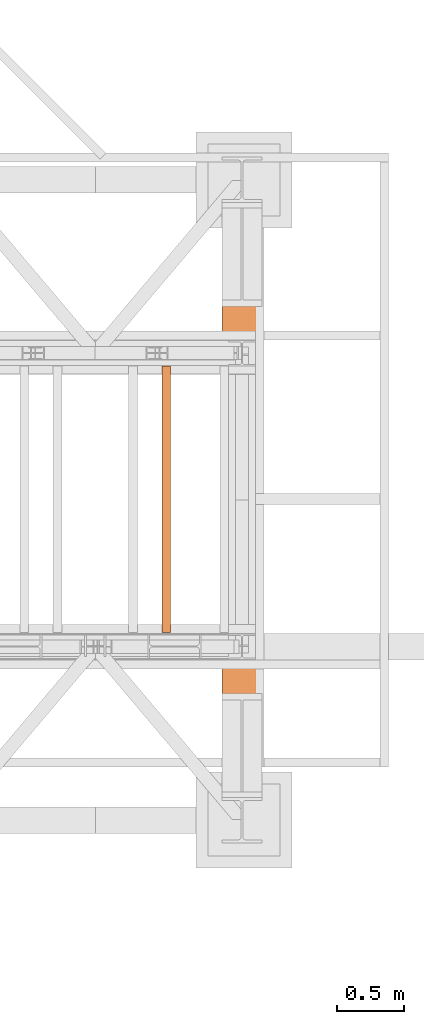
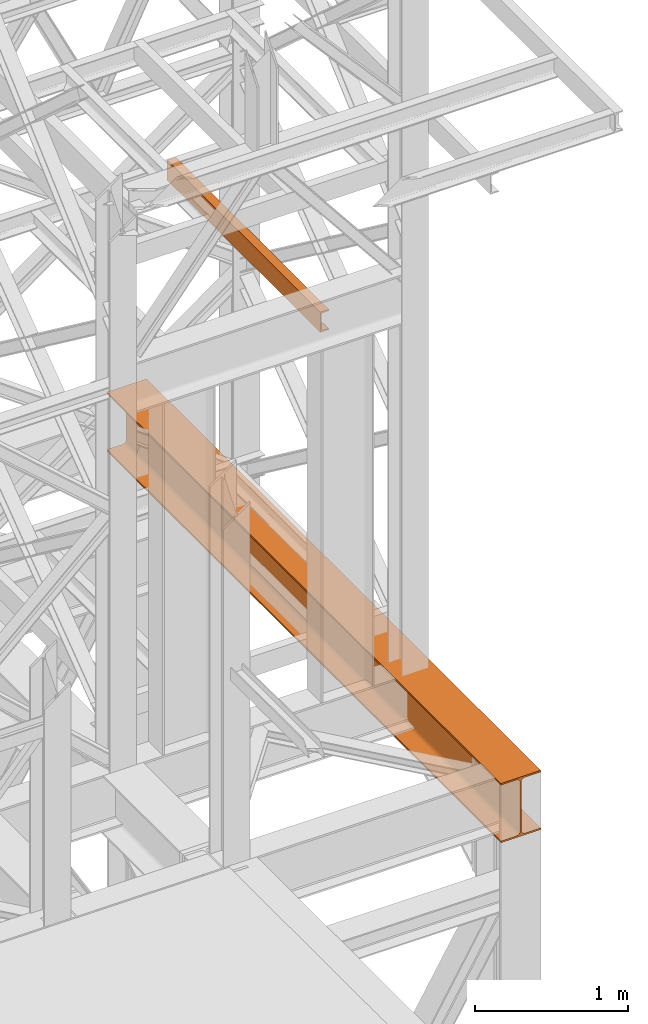
# One storey, part 182 of 208: 2 proxies.
"""IFC2X3 building model written with IfcOpenShell, lengths in millimetres."""

from ifc_helpers import new_model, entity, si_unit, converted_unit, frame, origin, origin_with_axes, place, context, subcontext, project, spatial, faceted_brep, element, save


model = new_model("IFC2X3")

# Units and contexts
model_context = context("Model", 3, precision=1e-05, world=origin())
plan_context = context("Plan", 3, precision=1e-05, world=origin())
body_context = subcontext(model_context, "Body", "Model", "MODEL_VIEW")
ifc_project = project(units=[si_unit("LENGTHUNIT", "METRE", prefix="MILLI"), converted_unit("PLANEANGLEUNIT", "DEGREE", entity("IfcPlaneAngleMeasure", 0.0174532925199433), si_unit("PLANEANGLEUNIT", "RADIAN"), dimensions=[0, 0, 0, 0, 0, 0, 0]), si_unit("AREAUNIT", "SQUARE_METRE"), si_unit("VOLUMEUNIT", "CUBIC_METRE")], contexts=[model_context, plan_context])

# Building, storey
building_placement = place(None, origin())
building = spatial("IfcBuilding", under=ifc_project, at=building_placement, CompositionType="COMPLEX")
storey_placement = place(building_placement, origin_with_axes())
storey = spatial("IfcBuildingStorey", under=building, at=storey_placement, Name="Geschoss", CompositionType="ELEMENT")

# Proxies
proxy_1_placement = place(storey_placement, frame((8643.254974489131, -17432.57439531566, 4812.990005364416), z_axis=(0.0, 0.0, 1.0), x_axis=(1.0, 0.0, 0.0)))
element("IfcBuildingElementProxy", 1, at=proxy_1_placement, inside=storey, context=body_context, shape_type="Brep", body=[
    faceted_brep([(300.0100000000002, 0.00999999999839929, 472.0100000000002), (300.0100000000002, 5140.010003576275, 472.0100000000002), (300.0100000000002, 5140.010003576275, 458.0100000000002), (300.0100000000002, 0.00999999999839929, 458.0100000000002), (300.0100000000002, 0.00999999999839929, 458.0100000000002), (300.0100000000002, 5140.010003576275, 458.0100000000002), (182.2600000000002, 5140.010003576275, 458.0100000000002), (182.2600000000002, 0.00999999999839929, 458.0100000000002), (182.2600000000002, 0.00999999999839929, 458.0100000000002), (182.2600000000002, 5140.010003576275, 458.0100000000002), (173.9165694541389, 5140.010003576275, 456.6884339422595), (173.9165694541389, 0.00999999999839929, 456.6884339422595), (173.9165694541389, 0.00999999999839929, 456.6884339422595), (173.9165694541389, 5140.010003576275, 456.6884339422595), (166.3898249342001, 5140.010003576275, 452.8534254634024), (166.3898249342001, 0.00999999999839929, 452.8534254634024), (166.3898249342001, 0.00999999999839929, 452.8534254634024), (166.3898249342001, 5140.010003576275, 452.8534254634024), (160.416574536599, 5140.010003576275, 446.8801750658013), (160.416574536599, 0.00999999999839929, 446.8801750658013), (160.416574536599, 0.00999999999839929, 446.8801750658013), (160.416574536599, 5140.010003576275, 446.8801750658013), (156.5815660577409, 5140.010003576275, 439.3534305458607), (156.5815660577409, 0.00999999999839929, 439.3534305458607), (156.5815660577409, 0.00999999999839929, 439.3534305458607), (156.5815660577409, 5140.010003576275, 439.3534305458607), (155.2600000000002, 5140.010003576275, 431.0100000000002), (155.2600000000002, 0.00999999999839929, 431.0100000000002), (155.2600000000002, 0.00999999999839929, 431.0100000000002), (155.2600000000002, 5140.010003576275, 431.0100000000002), (155.2600000000002, 5140.010003576275, 41.01000000000022), (155.2600000000002, 0.00999999999839929, 41.01000000000022), (155.2600000000002, 0.00999999999839929, 41.01000000000022), (155.2600000000002, 5140.010003576275, 41.01000000000022), (156.5815660577409, 5140.010003576275, 32.66656945413979), (156.5815660577409, 0.00999999999839929, 32.66656945413979), (156.5815660577409, 0.00999999999839929, 32.66656945413979), (156.5815660577409, 5140.010003576275, 32.66656945413979), (160.416574536599, 5140.010003576275, 25.13982493419826), (160.416574536599, 0.00999999999839929, 25.13982493419826), (160.416574536599, 0.00999999999839929, 25.13982493419826), (160.416574536599, 5140.010003576275, 25.13982493419826), (166.3898249342001, 5140.010003576275, 19.16657453659809), (166.3898249342001, 0.00999999999839929, 19.16657453659809), (166.3898249342001, 0.00999999999839929, 19.16657453659809), (166.3898249342001, 5140.010003576275, 19.16657453659809), (173.9165694541389, 5140.010003576275, 15.33156605774093), (173.9165694541389, 0.00999999999839929, 15.33156605774093), (173.9165694541389, 0.00999999999839929, 15.33156605774093), (173.9165694541389, 5140.010003576275, 15.33156605774093), (182.2600000000002, 5140.010003576275, 14.01000000000022), (182.2600000000002, 0.00999999999839929, 14.01000000000022), (182.2600000000002, 0.00999999999839929, 14.01000000000022), (182.2600000000002, 5140.010003576275, 14.01000000000022), (300.0100000000002, 5140.010003576275, 14.01000000000022), (300.0100000000002, 0.00999999999839929, 14.01000000000022), (300.0100000000002, 0.00999999999839929, 14.01000000000022), (300.0100000000002, 5140.010003576275, 14.01000000000022), (300.0100000000002, 5140.010003576275, 0.01000000000021828), (300.0100000000002, 0.00999999999839929, 0.01000000000021828), (300.0100000000002, 0.00999999999839929, 0.01000000000021828), (300.0100000000002, 5140.010003576275, 0.01000000000021828), (0.01000000000021828, 5140.010003576275, 0.01000000000021828), (0.01000000000021828, 0.00999999999839929, 0.01000000000021828), (0.01000000000021828, 0.00999999999839929, 0.01000000000021828), (0.01000000000021828, 5140.010003576275, 0.01000000000021828), (0.01000000000021828, 5140.010003576275, 14.01000000000022), (0.01000000000021828, 0.00999999999839929, 14.01000000000022), (0.01000000000021828, 0.00999999999839929, 14.01000000000022), (0.01000000000021828, 5140.010003576275, 14.01000000000022), (117.7600000000002, 5140.010003576275, 14.01000000000022), (117.7600000000002, 0.00999999999839929, 14.01000000000022), (117.7600000000002, 0.00999999999839929, 14.01000000000022), (117.7600000000002, 5140.010003576275, 14.01000000000022), (126.1034305458616, 5140.010003576275, 15.33156605774093), (126.1034305458616, 0.00999999999839929, 15.33156605774093), (126.1034305458616, 0.00999999999839929, 15.33156605774093), (126.1034305458616, 5140.010003576275, 15.33156605774093), (133.6301750658004, 5140.010003576275, 19.16657453659809), (133.6301750658004, 0.00999999999839929, 19.16657453659809), (133.6301750658004, 0.00999999999839929, 19.16657453659809), (133.6301750658004, 5140.010003576275, 19.16657453659809), (139.6034254634014, 5140.010003576275, 25.13982493419826), (139.6034254634014, 0.00999999999839929, 25.13982493419826), (139.6034254634014, 0.00999999999839929, 25.13982493419826), (139.6034254634014, 5140.010003576275, 25.13982493419826), (143.4384339422595, 5140.010003576275, 32.66656945413979), (143.4384339422595, 0.00999999999839929, 32.66656945413979), (143.4384339422595, 0.00999999999839929, 32.66656945413979), (143.4384339422595, 5140.010003576275, 32.66656945413979), (144.7600000000002, 5140.010003576275, 41.01000000000022), (144.7600000000002, 0.00999999999839929, 41.01000000000022), (144.7600000000002, 0.00999999999839929, 41.01000000000022), (144.7600000000002, 5140.010003576275, 41.01000000000022), (144.7600000000002, 5140.010003576275, 431.0100000000002), (144.7600000000002, 0.00999999999839929, 431.0100000000002), (144.7600000000002, 0.00999999999839929, 431.0100000000002), (144.7600000000002, 5140.010003576275, 431.0100000000002), (143.4384339422595, 5140.010003576275, 439.3534305458607), (143.4384339422595, 0.00999999999839929, 439.3534305458607), (143.4384339422595, 0.00999999999839929, 439.3534305458607), (143.4384339422595, 5140.010003576275, 439.3534305458607), (139.6034254634014, 5140.010003576275, 446.8801750658013), (139.6034254634014, 0.00999999999839929, 446.8801750658013), (139.6034254634014, 0.00999999999839929, 446.8801750658013), (139.6034254634014, 5140.010003576275, 446.8801750658013), (133.6301750658004, 5140.010003576275, 452.8534254634024), (133.6301750658004, 0.00999999999839929, 452.8534254634024), (133.6301750658004, 0.00999999999839929, 452.8534254634024), (133.6301750658004, 5140.010003576275, 452.8534254634024), (126.1034305458616, 5140.010003576275, 456.6884339422595), (126.1034305458616, 0.00999999999839929, 456.6884339422595), (126.1034305458616, 0.00999999999839929, 456.6884339422595), (126.1034305458616, 5140.010003576275, 456.6884339422595), (117.7600000000002, 5140.010003576275, 458.0100000000002), (117.7600000000002, 0.00999999999839929, 458.0100000000002), (117.7600000000002, 0.00999999999839929, 458.0100000000002), (117.7600000000002, 5140.010003576275, 458.0100000000002), (0.01000000000021828, 5140.010003576275, 458.0100000000002), (0.01000000000021828, 0.00999999999839929, 458.0100000000002), (0.01000000000021828, 0.00999999999839929, 458.0100000000002), (0.01000000000021828, 5140.010003576275, 458.0100000000002), (0.01000000000021828, 5140.010003576275, 472.0100000000002), (0.01000000000021828, 0.00999999999839929, 472.0100000000002), (0.01000000000021828, 0.00999999999839929, 472.0100000000002), (0.01000000000021828, 5140.010003576275, 472.0100000000002), (300.0100000000002, 5140.010003576275, 472.0100000000002), (300.0100000000002, 0.00999999999839929, 472.0100000000002), (300.0100000000002, 0.00999999999839929, 472.0100000000002), (300.0100000000002, 0.00999999999839929, 458.0100000000002), (182.2600000000002, 0.00999999999839929, 458.0100000000002), (173.9165694541389, 0.00999999999839929, 456.6884339422595), (166.3898249342001, 0.00999999999839929, 452.8534254634024), (160.416574536599, 0.00999999999839929, 446.8801750658013), (156.5815660577409, 0.00999999999839929, 439.3534305458607), (155.2600000000002, 0.00999999999839929, 431.0100000000002), (155.2600000000002, 0.00999999999839929, 41.01000000000022), (156.5815660577409, 0.00999999999839929, 32.66656945413979), (160.416574536599, 0.00999999999839929, 25.13982493419826), (166.3898249342001, 0.00999999999839929, 19.16657453659809), (173.9165694541389, 0.00999999999839929, 15.33156605774093), (182.2600000000002, 0.00999999999839929, 14.01000000000022), (300.0100000000002, 0.00999999999839929, 14.01000000000022), (300.0100000000002, 0.00999999999839929, 0.01000000000021828), (0.01000000000021828, 0.00999999999839929, 0.01000000000021828), (0.01000000000021828, 0.00999999999839929, 14.01000000000022), (117.7600000000002, 0.00999999999839929, 14.01000000000022), (126.1034305458616, 0.00999999999839929, 15.33156605774093), (133.6301750658004, 0.00999999999839929, 19.16657453659809), (139.6034254634014, 0.00999999999839929, 25.13982493419826), (143.4384339422595, 0.00999999999839929, 32.66656945413979), (144.7600000000002, 0.00999999999839929, 41.01000000000022), (144.7600000000002, 0.00999999999839929, 431.0100000000002), (143.4384339422595, 0.00999999999839929, 439.3534305458607), (139.6034254634014, 0.00999999999839929, 446.8801750658013), (133.6301750658004, 0.00999999999839929, 452.8534254634024), (126.1034305458616, 0.00999999999839929, 456.6884339422595), (117.7600000000002, 0.00999999999839929, 458.0100000000002), (0.01000000000021828, 0.00999999999839929, 458.0100000000002), (0.01000000000021828, 0.00999999999839929, 472.0100000000002), (300.0100000000002, 5140.010003576275, 472.0100000000002), (0.01000000000021828, 5140.010003576275, 472.0100000000002), (0.01000000000021828, 5140.010003576275, 458.0100000000002), (117.7600000000002, 5140.010003576275, 458.0100000000002), (126.1034305458616, 5140.010003576275, 456.6884339422595), (133.6301750658004, 5140.010003576275, 452.8534254634024), (139.6034254634014, 5140.010003576275, 446.8801750658013), (143.4384339422595, 5140.010003576275, 439.3534305458607), (144.7600000000002, 5140.010003576275, 431.0100000000002), (144.7600000000002, 5140.010003576275, 41.01000000000022), (143.4384339422595, 5140.010003576275, 32.66656945413979), (139.6034254634014, 5140.010003576275, 25.13982493419826), (133.6301750658004, 5140.010003576275, 19.16657453659809), (126.1034305458616, 5140.010003576275, 15.33156605774093), (117.7600000000002, 5140.010003576275, 14.01000000000022), (0.01000000000021828, 5140.010003576275, 14.01000000000022), (0.01000000000021828, 5140.010003576275, 0.01000000000021828), (300.0100000000002, 5140.010003576275, 0.01000000000021828), (300.0100000000002, 5140.010003576275, 14.01000000000022), (182.2600000000002, 5140.010003576275, 14.01000000000022), (173.9165694541389, 5140.010003576275, 15.33156605774093), (166.3898249342001, 5140.010003576275, 19.16657453659809), (160.416574536599, 5140.010003576275, 25.13982493419826), (156.5815660577409, 5140.010003576275, 32.66656945413979), (155.2600000000002, 5140.010003576275, 41.01000000000022), (155.2600000000002, 5140.010003576275, 431.0100000000002), (156.5815660577409, 5140.010003576275, 439.3534305458607), (160.416574536599, 5140.010003576275, 446.8801750658013), (166.3898249342001, 5140.010003576275, 452.8534254634024), (173.9165694541389, 5140.010003576275, 456.6884339422595), (182.2600000000002, 5140.010003576275, 458.0100000000002), (300.0100000000002, 5140.010003576275, 458.0100000000002)], [[[0, 1, 2, 3]], [[4, 5, 6, 7]], [[8, 9, 10, 11]], [[12, 13, 14, 15]], [[16, 17, 18, 19]], [[20, 21, 22, 23]], [[24, 25, 26, 27]], [[28, 29, 30, 31]], [[32, 33, 34, 35]], [[36, 37, 38, 39]], [[40, 41, 42, 43]], [[44, 45, 46, 47]], [[48, 49, 50, 51]], [[52, 53, 54, 55]], [[56, 57, 58, 59]], [[60, 61, 62, 63]], [[64, 65, 66, 67]], [[68, 69, 70, 71]], [[72, 73, 74, 75]], [[76, 77, 78, 79]], [[80, 81, 82, 83]], [[84, 85, 86, 87]], [[88, 89, 90, 91]], [[92, 93, 94, 95]], [[96, 97, 98, 99]], [[100, 101, 102, 103]], [[104, 105, 106, 107]], [[108, 109, 110, 111]], [[112, 113, 114, 115]], [[116, 117, 118, 119]], [[120, 121, 122, 123]], [[124, 125, 126, 127]], [[128, 129, 130, 131, 132, 133, 134, 135, 136, 137, 138, 139, 140, 141, 142, 143, 144, 145, 146, 147, 148, 149, 150, 151, 152, 153, 154, 155, 156, 157, 158, 159]], [[160, 161, 162, 163, 164, 165, 166, 167, 168, 169, 170, 171, 172, 173, 174, 175, 176, 177, 178, 179, 180, 181, 182, 183, 184, 185, 186, 187, 188, 189, 190, 191]]], orient=[[False], [False], [False], [False], [False], [False], [False], [False], [False], [False], [False], [False], [False], [False], [False], [False], [False], [False], [False], [False], [False], [False], [False], [False], [False], [False], [False], [False], [False], [False], [False], [False], [False], [False]]),
])
proxy_2_placement = place(storey_placement, frame((8193.254968528667, -15857.57439274273, 8078.360005364418), z_axis=(0.0, 0.0, 1.0), x_axis=(1.0, 0.0, 0.0)))
element("IfcBuildingElementProxy", 2, at=proxy_2_placement, inside=storey, context=body_context, shape_type="Brep", body=[
    faceted_brep([(0.01000000000021828, 2000.009997019768, 160.0099999999993), (65.01000000000022, 2000.009997019768, 160.0099999999993), (65.0099999999984, 0.01000000000021828, 160.0099999999993), (0.00999999999839929, 0.01000000000021828, 160.0099999999993), (65.01000000000022, 2000.009997019768, 160.0099999999993), (65.01000000000022, 2000.009997019768, 156.8875719297548), (65.0099999999984, 0.01000000000021828, 156.8875719297548), (65.0099999999984, 0.01000000000021828, 160.0099999999993), (65.01000000000022, 2000.009997019768, 156.8875719297548), (64.76726342282745, 2000.009997019768, 155.2717110918284), (64.76726342282564, 0.01000000000021828, 155.2717110918284), (65.0099999999984, 0.01000000000021828, 156.8875719297548), (64.76726342282745, 2000.009997019768, 155.2717110918284), (64.06053228585552, 2000.009997019768, 153.7984655565533), (64.06053228585733, 0.01000000000021828, 153.7984655565533), (64.76726342282564, 0.01000000000021828, 155.2717110918284), (64.06053228585552, 2000.009997019768, 153.7984655565533), (62.95215163846842, 2000.009997019768, 152.5978732961276), (62.9521516384666, 0.01000000000021828, 152.5978732961276), (64.06053228585733, 0.01000000000021828, 153.7984655565533), (62.95215163846842, 2000.009997019768, 152.5978732961276), (61.53995641148322, 2000.009997019768, 151.7759086082888), (61.5399564114814, 0.01000000000021828, 151.7759086082888), (62.9521516384666, 0.01000000000021828, 152.5978732961276), (61.53995641148322, 2000.009997019768, 151.7759086082888), (59.94859872255438, 2000.009997019768, 151.405087897806), (59.94859872255256, 0.01000000000021828, 151.405087897806), (61.5399564114814, 0.01000000000021828, 151.7759086082888), (59.94859872255438, 2000.009997019768, 151.405087897806), (17.17267516602988, 2000.009997019768, 147.9830140132845), (17.17267516602806, 0.01000000000021828, 147.9830140132845), (59.94859872255256, 0.01000000000021828, 151.405087897806), (17.17267516602988, 2000.009997019768, 147.9830140132845), (14.20840820800913, 2000.009997019768, 147.3180267615289), (14.20840820800731, 0.01000000000021828, 147.3180267615289), (17.17267516602806, 0.01000000000021828, 147.9830140132845), (14.20840820800913, 2000.009997019768, 147.3180267615289), (11.43861959928654, 2000.009997019768, 145.705878252852), (11.43861959928836, 0.01000000000021828, 145.705878252852), (14.20840820800731, 0.01000000000021828, 147.3180267615289), (11.43861959928654, 2000.009997019768, 145.705878252852), (9.322620181546881, 2000.009997019768, 143.413838482943), (9.322620181545062, 0.01000000000021828, 143.413838482943), (11.43861959928836, 0.01000000000021828, 145.705878252852), (9.322620181546881, 2000.009997019768, 143.413838482943), (7.97340619278657, 2000.009997019768, 140.6012788246926), (7.973406192784751, 0.01000000000021828, 140.6012788246926), (9.322620181545062, 0.01000000000021828, 143.413838482943), (7.97340619278657, 2000.009997019768, 140.6012788246926), (7.510000000000218, 2000.009997019768, 137.5164535886552), (7.509999999998399, 0.01000000000021828, 137.5164535886552), (7.973406192784751, 0.01000000000021828, 140.6012788246926), (7.510000000000218, 2000.009997019768, 137.5164535886552), (7.510000000000218, 2000.009997019768, 22.503546411348), (7.509999999998399, 0.01000000000021828, 22.503546411348), (7.509999999998399, 0.01000000000021828, 137.5164535886552), (7.510000000000218, 2000.009997019768, 22.503546411348), (7.97340619278657, 2000.009997019768, 19.41872117530875), (7.973406192784751, 0.01000000000021828, 19.41872117530875), (7.509999999998399, 0.01000000000021828, 22.503546411348), (7.97340619278657, 2000.009997019768, 19.41872117530875), (9.322620181546881, 2000.009997019768, 16.60616151705835), (9.322620181545062, 0.01000000000021828, 16.60616151705835), (7.973406192784751, 0.01000000000021828, 19.41872117530875), (9.322620181546881, 2000.009997019768, 16.60616151705835), (11.43861959928654, 2000.009997019768, 14.31412174714933), (11.43861959928836, 0.01000000000021828, 14.31412174714933), (9.322620181545062, 0.01000000000021828, 16.60616151705835), (11.43861959928654, 2000.009997019768, 14.31412174714933), (14.13462866898226, 2000.009997019768, 12.74491643400688), (14.13462866898408, 0.01000000000021828, 12.74491643400688), (11.43861959928836, 0.01000000000021828, 14.31412174714933), (14.13462866898226, 2000.009997019768, 12.74491643400688), (17.17267516602988, 2000.009997019768, 12.03698598671872), (17.17267516602806, 0.01000000000021828, 12.03698598671872), (14.13462866898408, 0.01000000000021828, 12.74491643400688), (17.17267516602988, 2000.009997019768, 12.03698598671872), (59.94859872255438, 2000.009997019768, 8.614912102195376), (59.94859872255256, 0.01000000000021828, 8.614912102195376), (17.17267516602806, 0.01000000000021828, 12.03698598671872), (59.94859872255438, 2000.009997019768, 8.614912102195376), (61.53995641148322, 2000.009997019768, 8.244091391710754), (61.5399564114814, 0.01000000000021828, 8.244091391710754), (59.94859872255256, 0.01000000000021828, 8.614912102195376), (61.53995641148322, 2000.009997019768, 8.244091391710754), (62.95215163846842, 2000.009997019768, 7.422126703873801), (62.9521516384666, 0.01000000000021828, 7.422126703873801), (61.5399564114814, 0.01000000000021828, 8.244091391710754), (62.95215163846842, 2000.009997019768, 7.422126703873801), (64.06053228585552, 2000.009997019768, 6.221534443446217), (64.06053228585733, 0.01000000000021828, 6.221534443446217), (62.9521516384666, 0.01000000000021828, 7.422126703873801), (64.06053228585552, 2000.009997019768, 6.221534443446217), (64.76726342282745, 2000.009997019768, 4.748288908172981), (64.76726342282564, 0.01000000000021828, 4.748288908172981), (64.06053228585733, 0.01000000000021828, 6.221534443446217), (64.76726342282745, 2000.009997019768, 4.748288908172981), (65.01000000000022, 2000.009997019768, 0.01000000000021828), (65.0099999999984, 0.01000000000021828, 0.01000000000021828), (64.76726342282564, 0.01000000000021828, 4.748288908172981), (65.01000000000022, 2000.009997019768, 0.01000000000021828), (0.01000000000021828, 2000.009997019768, 0.01000000000021828), (0.00999999999839929, 0.01000000000021828, 0.01000000000021828), (65.0099999999984, 0.01000000000021828, 0.01000000000021828), (0.01000000000021828, 2000.009997019768, 0.01000000000021828), (0.01000000000021828, 2000.009997019768, 160.0099999999993), (0.00999999999839929, 0.01000000000021828, 160.0099999999993), (0.00999999999839929, 0.01000000000021828, 0.01000000000021828), (0.01000000000021828, 2000.009997019768, 160.0099999999993), (0.01000000000021828, 2000.009997019768, 0.01000000000021828), (65.01000000000022, 2000.009997019768, 0.01000000000021828), (64.76726342282745, 2000.009997019768, 4.748288908172981), (64.06053228585552, 2000.009997019768, 6.221534443446217), (62.95215163846842, 2000.009997019768, 7.422126703873801), (61.53995641148322, 2000.009997019768, 8.244091391710754), (59.94859872255438, 2000.009997019768, 8.614912102195376), (17.17267516602988, 2000.009997019768, 12.03698598671872), (14.13462866898226, 2000.009997019768, 12.74491643400688), (11.43861959928654, 2000.009997019768, 14.31412174714933), (9.322620181546881, 2000.009997019768, 16.60616151705835), (7.97340619278657, 2000.009997019768, 19.41872117530875), (7.510000000000218, 2000.009997019768, 22.503546411348), (7.510000000000218, 2000.009997019768, 137.5164535886552), (7.97340619278657, 2000.009997019768, 140.6012788246926), (9.322620181546881, 2000.009997019768, 143.413838482943), (11.43861959928654, 2000.009997019768, 145.705878252852), (14.20840820800913, 2000.009997019768, 147.3180267615289), (17.17267516602988, 2000.009997019768, 147.9830140132845), (59.94859872255438, 2000.009997019768, 151.405087897806), (61.53995641148322, 2000.009997019768, 151.7759086082888), (62.95215163846842, 2000.009997019768, 152.5978732961276), (64.06053228585552, 2000.009997019768, 153.7984655565533), (64.76726342282745, 2000.009997019768, 155.2717110918284), (65.01000000000022, 2000.009997019768, 156.8875719297548), (65.01000000000022, 2000.009997019768, 160.0099999999993), (0.00999999999839929, 0.01000000000021828, 160.0099999999993), (65.0099999999984, 0.01000000000021828, 160.0099999999993), (65.0099999999984, 0.01000000000021828, 156.8875719297548), (64.76726342282564, 0.01000000000021828, 155.2717110918284), (64.06053228585733, 0.01000000000021828, 153.7984655565533), (62.9521516384666, 0.01000000000021828, 152.5978732961276), (61.5399564114814, 0.01000000000021828, 151.7759086082888), (59.94859872255256, 0.01000000000021828, 151.405087897806), (17.17267516602806, 0.01000000000021828, 147.9830140132845), (14.20840820800731, 0.01000000000021828, 147.3180267615289), (11.43861959928836, 0.01000000000021828, 145.705878252852), (9.322620181545062, 0.01000000000021828, 143.413838482943), (7.973406192784751, 0.01000000000021828, 140.6012788246926), (7.509999999998399, 0.01000000000021828, 137.5164535886552), (7.509999999998399, 0.01000000000021828, 22.503546411348), (7.973406192784751, 0.01000000000021828, 19.41872117530875), (9.322620181545062, 0.01000000000021828, 16.60616151705835), (11.43861959928836, 0.01000000000021828, 14.31412174714933), (14.13462866898408, 0.01000000000021828, 12.74491643400688), (17.17267516602806, 0.01000000000021828, 12.03698598671872), (59.94859872255256, 0.01000000000021828, 8.614912102195376), (61.5399564114814, 0.01000000000021828, 8.244091391710754), (62.9521516384666, 0.01000000000021828, 7.422126703873801), (64.06053228585733, 0.01000000000021828, 6.221534443446217), (64.76726342282564, 0.01000000000021828, 4.748288908172981), (65.0099999999984, 0.01000000000021828, 0.01000000000021828), (0.00999999999839929, 0.01000000000021828, 0.01000000000021828)], [[[0, 1, 2, 3]], [[4, 5, 6, 7]], [[8, 9, 10, 11]], [[12, 13, 14, 15]], [[16, 17, 18, 19]], [[20, 21, 22, 23]], [[24, 25, 26, 27]], [[28, 29, 30, 31]], [[32, 33, 34, 35]], [[36, 37, 38, 39]], [[40, 41, 42, 43]], [[44, 45, 46, 47]], [[48, 49, 50, 51]], [[52, 53, 54, 55]], [[56, 57, 58, 59]], [[60, 61, 62, 63]], [[64, 65, 66, 67]], [[68, 69, 70, 71]], [[72, 73, 74, 75]], [[76, 77, 78, 79]], [[80, 81, 82, 83]], [[84, 85, 86, 87]], [[88, 89, 90, 91]], [[92, 93, 94, 95]], [[96, 97, 98, 99]], [[100, 101, 102, 103]], [[104, 105, 106, 107]], [[108, 109, 110, 111, 112, 113, 114, 115, 116, 117, 118, 119, 120, 121, 122, 123, 124, 125, 126, 127, 128, 129, 130, 131, 132, 133, 134]], [[135, 136, 137, 138, 139, 140, 141, 142, 143, 144, 145, 146, 147, 148, 149, 150, 151, 152, 153, 154, 155, 156, 157, 158, 159, 160, 161]]], orient=[[False], [False], [False], [False], [False], [False], [False], [False], [False], [False], [False], [False], [False], [False], [False], [False], [False], [False], [False], [False], [False], [False], [False], [False], [False], [False], [False], [False], [False]]),
])

save(model, "model.ifc")
